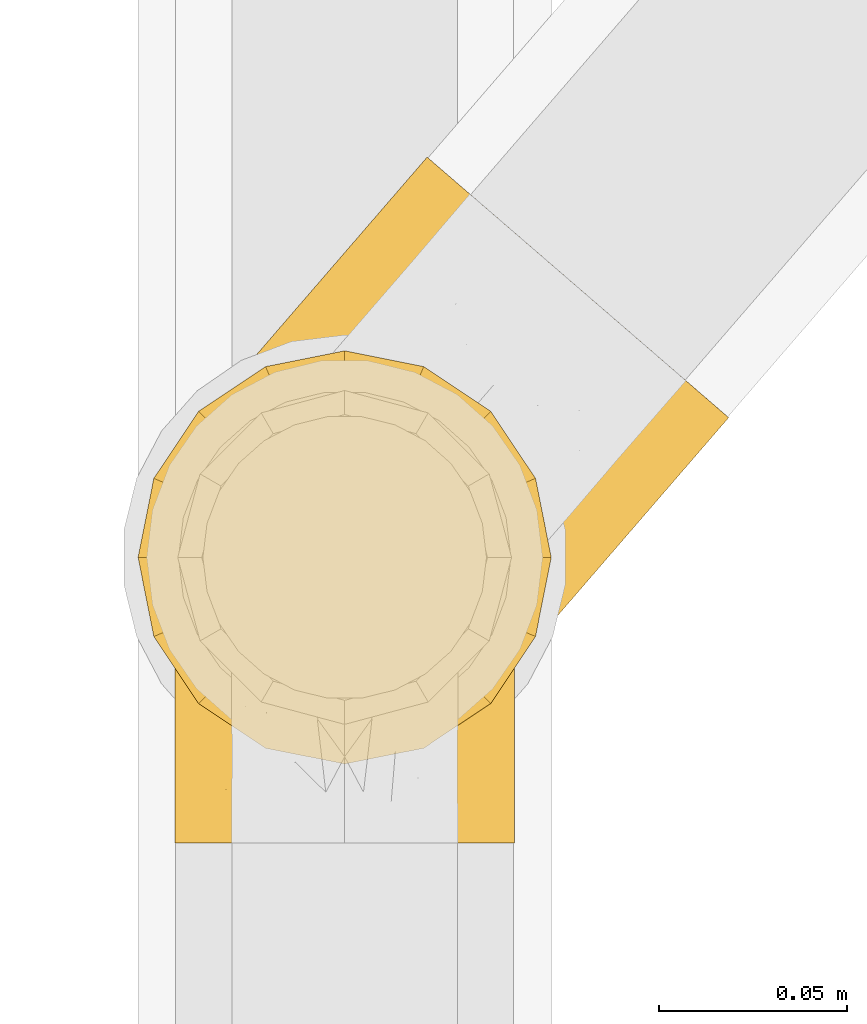
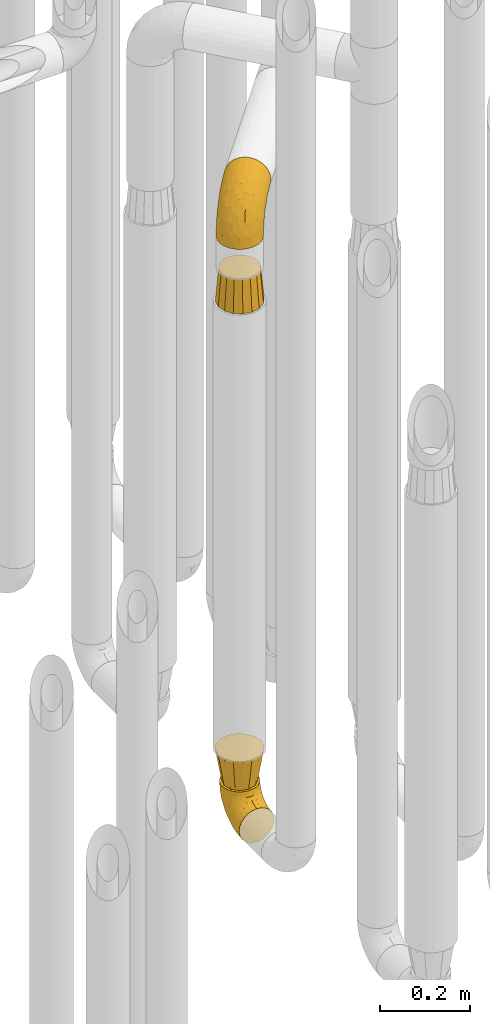
# One storey, part 215 of 827: 4 coverings.
"""IFC2X3 building model written with IfcOpenShell, lengths in millimetres."""

from ifc_helpers import new_model, entity, si_unit, converted_unit, derived_unit, direction, frame, origin, place, context, subcontext, project, spatial, faceted_brep, element, save


model = new_model("IFC2X3")

# Units and contexts
model_context = context("Model", 3, precision=0.01, world=origin(), true_north=direction((6.12303176911189e-17, 1.0)))
body_context = subcontext(model_context, "Body", "Model", "MODEL_VIEW")
ifc_project = project(units=[si_unit("LENGTHUNIT", "METRE", prefix="MILLI"), si_unit("AREAUNIT", "SQUARE_METRE"), si_unit("VOLUMEUNIT", "CUBIC_METRE"), converted_unit("PLANEANGLEUNIT", "DEGREE", entity("IfcRatioMeasure", 0.0174532925199433), si_unit("PLANEANGLEUNIT", "RADIAN"), dimensions=[0, 0, 0, 0, 0, 0, 0]), si_unit("MASSUNIT", "GRAM", prefix="KILO"), derived_unit("MASSDENSITYUNIT", [(si_unit("MASSUNIT", "GRAM", prefix="KILO"), 1), (si_unit("LENGTHUNIT", "METRE"), -3)]), derived_unit("MOMENTOFINERTIAUNIT", [(si_unit("LENGTHUNIT", "METRE"), 4)]), si_unit("TIMEUNIT", "SECOND"), si_unit("FREQUENCYUNIT", "HERTZ"), si_unit("THERMODYNAMICTEMPERATUREUNIT", "DEGREE_CELSIUS"), derived_unit("THERMALTRANSMITTANCEUNIT", [(si_unit("MASSUNIT", "GRAM", prefix="KILO"), 1), (si_unit("THERMODYNAMICTEMPERATUREUNIT", "KELVIN"), -1), (si_unit("TIMEUNIT", "SECOND"), -3)]), derived_unit("VOLUMETRICFLOWRATEUNIT", [(si_unit("LENGTHUNIT", "METRE"), 3), (si_unit("TIMEUNIT", "SECOND"), -1)]), derived_unit("MASSFLOWRATEUNIT", [(si_unit("MASSUNIT", "GRAM", prefix="KILO"), 1), (si_unit("TIMEUNIT", "SECOND"), -1)]), derived_unit("ROTATIONALFREQUENCYUNIT", [(si_unit("TIMEUNIT", "SECOND"), -1)]), si_unit("ELECTRICCURRENTUNIT", "AMPERE"), si_unit("ELECTRICVOLTAGEUNIT", "VOLT"), si_unit("POWERUNIT", "WATT"), si_unit("FORCEUNIT", "NEWTON", prefix="KILO"), si_unit("ILLUMINANCEUNIT", "LUX"), si_unit("LUMINOUSFLUXUNIT", "LUMEN"), si_unit("LUMINOUSINTENSITYUNIT", "CANDELA"), derived_unit("USERDEFINED", [(si_unit("MASSUNIT", "GRAM", prefix="KILO"), -1), (si_unit("LENGTHUNIT", "METRE"), -2), (si_unit("TIMEUNIT", "SECOND"), 3), (si_unit("LUMINOUSFLUXUNIT", "LUMEN"), 1)]), derived_unit("LINEARVELOCITYUNIT", [(si_unit("LENGTHUNIT", "METRE"), 1), (si_unit("TIMEUNIT", "SECOND"), -1)]), si_unit("PRESSUREUNIT", "PASCAL"), derived_unit("USERDEFINED", [(si_unit("LENGTHUNIT", "METRE"), -2), (si_unit("MASSUNIT", "GRAM", prefix="KILO"), 1), (si_unit("TIMEUNIT", "SECOND"), -2)]), derived_unit("LINEARFORCEUNIT", [(si_unit("MASSUNIT", "GRAM", prefix="KILO"), 1), (si_unit("LENGTHUNIT", "METRE"), 1), (si_unit("TIMEUNIT", "SECOND"), -2), (si_unit("LENGTHUNIT", "METRE"), -1)]), derived_unit("PLANARFORCEUNIT", [(si_unit("MASSUNIT", "GRAM", prefix="KILO"), 1), (si_unit("LENGTHUNIT", "METRE"), 1), (si_unit("TIMEUNIT", "SECOND"), -2), (si_unit("LENGTHUNIT", "METRE"), -2)])], contexts=[model_context])

# Site, building, storey
site_placement = place(None, origin())
site = spatial("IfcSite", under=ifc_project, at=site_placement, CompositionType="ELEMENT")
building_placement = place(site_placement, origin())
building = spatial("IfcBuilding", under=site, at=building_placement, CompositionType="ELEMENT")
storey_placement = place(building_placement, frame((0.0, 0.0, 28200.0)))
storey = spatial("IfcBuildingStorey", under=building, at=storey_placement, Name="08", CompositionType="ELEMENT", Elevation=28200.0)

# Coverings
covering_1_placement = place(storey_placement, frame((36582.9, 11254.0, 353.25)))
element("IfcCovering", 1, at=covering_1_placement, inside=storey, Name=":ADSK_", ObjectType=":ADSK_", PredefinedType="INSULATION", context=body_context, shape_type="Brep", body=[
    faceted_brep([(90.76, 87.65, 122.75), (87.42, 97.19, 122.75), (82.04, 105.75, 122.75), (74.89, 112.9, 122.75), (66.33, 118.28, 122.75), (56.79, 121.61, 122.75), (46.75, 122.75, 122.75), (36.69, 121.61, 122.75), (27.15, 118.27, 122.75), (18.59, 112.89, 122.75), (11.44, 105.74, 122.75), (6.06, 97.18, 122.75), (2.73, 87.64, 122.75), (1.6, 77.6, 122.75), (2.73, 67.54, 122.75), (6.07, 58.0, 122.75), (11.45, 49.44, 122.75), (18.6, 42.29, 122.75), (27.16, 36.91, 122.75), (36.7, 33.58, 122.75), (46.75, 32.45, 122.75), (56.8, 33.58, 122.75), (66.34, 36.92, 122.75), (74.9, 42.3, 122.75), (82.05, 49.45, 122.75), (87.43, 58.01, 122.75), (90.76, 67.55, 122.75), (91.9, 77.6, 122.75), (35.06, 1.6, 90.36), (24.17, 1.6, 85.85), (14.82, 1.6, 78.67), (7.64, 1.6, 69.32), (3.13, 1.6, 58.43), (1.6, 1.6, 46.75), (3.13, 1.6, 35.06), (7.64, 1.6, 24.17), (14.82, 1.6, 14.82), (24.17, 1.6, 7.64), (35.06, 1.6, 3.13), (46.75, 1.6, 1.6), (58.43, 1.6, 3.13), (69.32, 1.6, 7.64), (78.67, 1.6, 14.82), (85.85, 1.6, 24.17), (90.36, 1.6, 35.06), (91.9, 1.6, 46.75), (90.36, 1.6, 58.43), (85.85, 1.6, 69.32), (78.67, 1.6, 78.67), (69.32, 1.6, 85.85), (58.43, 1.6, 90.36), (46.75, 1.6, 91.9), (46.75, 99.61, 51.54), (55.2, 95.26, 47.17), (46.75, 86.21, 38.13), (46.75, 39.03, 7.52), (54.53, 30.75, 5.85), (46.75, 23.8, 5.11), (59.63, 60.8, 19.2), (62.07, 85.37, 38.98), (71.86, 73.64, 35.02), (62.65, 31.01, 8.21), (71.33, 49.14, 19.28), (72.93, 23.88, 12.19), (91.2, 82.74, 101.39), (86.31, 43.48, 34.43), (80.89, 29.47, 20.95), (79.49, 56.38, 30.74), (90.68, 72.18, 72.93), (86.84, 72.24, 56.64), (87.38, 87.6, 80.81), (76.87, 107.24, 93.43), (83.73, 101.1, 100.76), (81.03, 95.16, 74.27), (91.9, 71.81, 93.66), (91.9, 63.57, 81.33), (91.9, 55.34, 69.01), (91.03, 23.66, 40.87), (87.58, 20.55, 29.38), (56.52, 107.97, 67.05), (46.75, 116.82, 85.31), (60.4, 117.03, 93.68), (91.9, 30.68, 52.53), (91.9, 21.51, 50.71), (91.9, 12.33, 48.88), (67.87, 106.17, 72.77), (90.35, 52.37, 51.21), (69.57, 114.51, 101.18), (46.75, 119.23, 100.54), (79.91, 78.37, 48.74), (91.9, 75.46, 112.01), (91.9, 73.63, 102.83), (74.99, 101.51, 73.88), (46.75, 72.81, 24.73), (91.9, 43.01, 60.77), (88.53, 92.6, 103.08), (72.65, 91.86, 54.8), (46.75, 55.92, 16.13), (62.97, 99.01, 55.92), (46.75, 108.21, 68.42), (66.2, 32.05, 104.98), (56.6, 30.22, 108.58), (59.89, 23.37, 98.21), (90.95, 28.43, 61.56), (90.22, 16.44, 60.69), (76.64, 37.1, 100.0), (71.58, 28.88, 95.88), (79.99, 33.93, 90.81), (89.54, 50.17, 84.88), (89.97, 40.57, 73.29), (81.32, 47.62, 113.4), (74.56, 39.9, 109.8), (84.15, 47.92, 102.13), (90.37, 34.27, 67.29), (87.82, 24.65, 70.34), (90.98, 62.6, 95.15), (90.96, 66.18, 105.49), (85.14, 11.74, 71.5), (58.11, 13.89, 92.87), (46.75, 17.02, 96.03), (78.39, 15.86, 81.34), (88.22, 57.71, 107.44), (66.06, 9.11, 88.36), (68.6, 18.55, 90.43), (63.78, 34.74, 114.37), (88.42, 54.95, 98.41), (90.61, 57.35, 88.73), (83.8, 22.03, 76.89), (77.98, 24.8, 86.08), (91.22, 69.07, 112.64), (83.46, 42.31, 94.21), (46.75, 29.63, 112.22), (46.75, 28.31, 107.32), (84.66, 30.23, 79.95), (86.33, 40.13, 84.51), (46.75, 22.67, 101.67), (46.75, 12.12, 94.71), (15.1, 15.86, 81.34), (9.69, 22.03, 76.89), (15.52, 24.8, 86.08), (8.83, 30.23, 79.96), (35.39, 13.88, 92.87), (12.18, 47.61, 113.41), (1.6, 73.63, 102.83), (2.53, 66.17, 105.5), (2.27, 69.07, 112.64), (36.9, 30.22, 108.58), (27.31, 32.04, 104.98), (33.62, 23.36, 98.2), (5.07, 54.93, 98.4), (9.36, 47.91, 102.13), (5.27, 57.69, 107.44), (27.43, 9.1, 88.36), (1.6, 21.51, 50.71), (1.6, 12.33, 48.88), (10.05, 42.29, 94.22), (16.87, 37.09, 100.01), (8.35, 11.74, 71.5), (3.27, 16.44, 60.69), (1.6, 30.68, 52.53), (21.94, 28.86, 95.89), (29.72, 34.74, 114.37), (1.6, 63.57, 81.33), (1.6, 55.34, 69.01), (3.96, 50.17, 84.88), (1.6, 75.46, 112.01), (18.95, 39.89, 109.8), (2.54, 28.43, 61.56), (3.12, 34.27, 67.29), (1.6, 43.01, 60.77), (2.51, 62.59, 95.14), (3.52, 40.57, 73.29), (7.17, 40.13, 84.53), (1.6, 71.81, 93.66), (13.52, 33.92, 90.82), (2.88, 57.34, 88.73), (5.67, 24.65, 70.34), (24.89, 18.54, 90.43), (12.6, 29.47, 20.95), (7.18, 43.48, 34.43), (14.0, 56.4, 30.74), (22.16, 49.17, 19.29), (21.61, 73.69, 35.07), (3.14, 52.37, 51.21), (6.65, 72.26, 56.67), (20.82, 91.88, 54.85), (31.41, 85.36, 38.98), (5.91, 20.55, 29.38), (2.46, 23.66, 40.87), (33.87, 60.8, 19.2), (30.84, 31.02, 8.21), (38.96, 30.75, 5.85), (20.56, 23.9, 12.19), (2.81, 72.17, 72.93), (6.1, 87.59, 80.83), (2.29, 82.74, 101.39), (33.08, 117.03, 93.69), (16.61, 107.23, 93.43), (36.96, 107.97, 67.04), (9.75, 101.08, 100.76), (25.61, 106.17, 72.78), (30.5, 99.01, 55.93), (23.91, 114.5, 101.18), (12.45, 95.15, 74.27), (18.49, 101.5, 73.89), (4.96, 92.59, 103.09), (13.56, 78.38, 48.78), (38.28, 95.27, 47.19)], [[[0, 1, 2, 3, 4, 5, 6, 7, 8, 9, 10, 11, 12, 13, 14, 15, 16, 17, 18, 19, 20, 21, 22, 23, 24, 25, 26, 27]], [[28, 29, 30, 31, 32, 33, 34, 35, 36, 37, 38, 39, 40, 41, 42, 43, 44, 45, 46, 47, 48, 49, 50, 51]], [[52, 53, 54]], [[55, 56, 57]], [[58, 59, 60]], [[61, 62, 63]], [[27, 64, 0]], [[65, 66, 67]], [[41, 40, 61]], [[68, 69, 70]], [[66, 43, 42]], [[63, 42, 41]], [[71, 72, 73]], [[72, 2, 1]], [[68, 74, 75, 76]], [[45, 44, 77]], [[43, 78, 44]], [[79, 80, 81]], [[77, 82, 83, 84, 45]], [[79, 81, 85]], [[71, 2, 72]], [[65, 86, 77]], [[4, 81, 5]], [[66, 65, 78]], [[4, 3, 87]], [[81, 88, 5]], [[63, 66, 42]], [[68, 70, 64]], [[67, 60, 89]], [[71, 3, 2]], [[64, 27, 90, 91, 74]], [[92, 71, 73]], [[40, 57, 56]], [[59, 93, 54]], [[86, 76, 94, 82]], [[1, 0, 95]], [[58, 62, 61]], [[60, 96, 89]], [[85, 81, 87]], [[56, 97, 58]], [[65, 67, 69]], [[87, 81, 4]], [[67, 89, 69]], [[61, 63, 41]], [[95, 72, 1]], [[73, 72, 70]], [[69, 73, 70]], [[73, 89, 96]], [[3, 71, 87]], [[85, 87, 71]], [[58, 61, 56]], [[59, 58, 93]], [[76, 86, 68]], [[69, 89, 73]], [[68, 86, 69]], [[65, 69, 86]], [[68, 64, 74]], [[95, 64, 70]], [[98, 79, 85]], [[79, 52, 99, 80]], [[66, 62, 67]], [[62, 58, 60]], [[62, 60, 67]], [[59, 98, 96]], [[59, 96, 60]], [[96, 85, 92]], [[88, 81, 80]], [[88, 6, 5]], [[66, 63, 62]], [[64, 95, 0]], [[72, 95, 70]], [[77, 44, 78]], [[86, 82, 77]], [[40, 39, 57]], [[96, 98, 85]], [[40, 56, 61]], [[66, 78, 43]], [[77, 78, 65]], [[79, 98, 53]], [[96, 92, 73]], [[85, 71, 92]], [[97, 56, 55]], [[97, 93, 58]], [[53, 98, 59]], [[54, 53, 59]], [[79, 53, 52]], [[100, 101, 102]], [[46, 45, 84, 83]], [[103, 104, 82]], [[82, 104, 83]], [[105, 106, 107]], [[108, 109, 76]], [[110, 111, 112]], [[103, 113, 114]], [[115, 74, 116]], [[48, 47, 117]], [[118, 102, 119]], [[49, 48, 120]], [[74, 91, 116]], [[116, 121, 115]], [[49, 122, 50]], [[123, 106, 102]], [[124, 111, 22]], [[125, 126, 115]], [[23, 22, 111]], [[24, 110, 121]], [[120, 127, 128]], [[90, 26, 129]], [[27, 26, 90]], [[121, 125, 115]], [[24, 121, 25]], [[130, 105, 107]], [[129, 25, 116]], [[21, 20, 131]], [[120, 123, 122]], [[112, 105, 130]], [[50, 118, 51]], [[21, 124, 22]], [[101, 131, 132]], [[117, 120, 48]], [[24, 23, 110]], [[127, 114, 133]], [[75, 108, 76]], [[107, 134, 130]], [[133, 114, 113]], [[129, 116, 91]], [[25, 121, 116]], [[121, 112, 125]], [[75, 74, 115]], [[101, 135, 102]], [[131, 101, 21]], [[101, 100, 124]], [[128, 127, 133]], [[119, 136, 51, 118]], [[104, 47, 46]], [[83, 104, 46]], [[117, 104, 114]], [[101, 124, 21]], [[111, 124, 100]], [[102, 118, 123]], [[133, 134, 107]], [[111, 110, 23]], [[114, 104, 103]], [[94, 76, 109]], [[121, 110, 112]], [[122, 118, 50]], [[134, 109, 108]], [[133, 107, 128]], [[112, 108, 125]], [[126, 125, 108]], [[108, 75, 126]], [[75, 115, 126]], [[109, 134, 133]], [[130, 108, 112]], [[108, 130, 134]], [[105, 112, 111]], [[111, 100, 105]], [[106, 105, 100]], [[102, 106, 100]], [[128, 106, 123]], [[90, 129, 91]], [[25, 129, 26]], [[104, 117, 47]], [[117, 114, 127]], [[82, 94, 103]], [[113, 94, 109]], [[94, 113, 103]], [[133, 113, 109]], [[106, 128, 107]], [[123, 120, 128]], [[120, 122, 49]], [[118, 122, 123]], [[135, 101, 132]], [[135, 119, 102]], [[117, 127, 120]], [[30, 29, 137]], [[138, 139, 140]], [[51, 136, 119, 141]], [[142, 17, 16]], [[143, 144, 145]], [[146, 147, 148]], [[149, 150, 151]], [[152, 29, 28]], [[33, 32, 153, 154]], [[150, 155, 156]], [[157, 31, 30]], [[153, 158, 159]], [[29, 152, 137]], [[148, 141, 119]], [[156, 160, 147]], [[148, 135, 146]], [[137, 138, 157]], [[19, 161, 146]], [[162, 163, 164]], [[14, 13, 165]], [[153, 32, 158]], [[147, 161, 166]], [[18, 17, 166]], [[167, 168, 169]], [[166, 150, 156]], [[151, 150, 142]], [[151, 170, 149]], [[151, 16, 15]], [[171, 140, 172]], [[165, 143, 145]], [[173, 170, 144]], [[142, 166, 17]], [[19, 131, 20]], [[144, 170, 151]], [[18, 161, 19]], [[173, 144, 143]], [[140, 139, 174]], [[171, 164, 163]], [[164, 172, 155]], [[151, 15, 144]], [[145, 15, 14]], [[173, 162, 170]], [[149, 175, 164]], [[19, 146, 131]], [[132, 131, 146]], [[160, 148, 147]], [[159, 158, 167]], [[135, 132, 146]], [[158, 32, 31]], [[157, 158, 31]], [[167, 158, 176]], [[166, 161, 18]], [[146, 161, 147]], [[148, 177, 141]], [[171, 168, 140]], [[171, 163, 169]], [[151, 142, 16]], [[166, 142, 150]], [[152, 141, 177]], [[51, 141, 28]], [[138, 140, 176]], [[172, 140, 174]], [[175, 149, 170]], [[164, 150, 149]], [[170, 162, 175]], [[162, 164, 175]], [[155, 172, 174]], [[171, 172, 164]], [[155, 174, 156]], [[164, 155, 150]], [[160, 156, 174]], [[147, 166, 156]], [[139, 160, 174]], [[148, 160, 177]], [[15, 145, 144]], [[165, 145, 14]], [[137, 157, 30]], [[158, 157, 176]], [[168, 167, 176]], [[169, 159, 167]], [[140, 168, 176]], [[169, 168, 171]], [[137, 177, 139]], [[160, 139, 177]], [[141, 152, 28]], [[137, 152, 177]], [[148, 119, 135]], [[157, 138, 176]], [[139, 138, 137]], [[178, 179, 180]], [[181, 180, 182]], [[179, 183, 184]], [[185, 186, 182]], [[187, 188, 179]], [[188, 33, 154, 153, 159]], [[181, 189, 190]], [[35, 34, 187]], [[191, 38, 190]], [[192, 178, 181]], [[179, 184, 180]], [[192, 190, 37]], [[37, 190, 38]], [[36, 35, 178]], [[54, 93, 186]], [[35, 187, 178]], [[193, 194, 184]], [[195, 173, 143, 165, 13]], [[195, 193, 173]], [[193, 163, 162, 173]], [[13, 12, 195]], [[8, 7, 196]], [[9, 197, 10]], [[198, 80, 99, 52]], [[196, 7, 88]], [[197, 199, 10]], [[182, 189, 181]], [[200, 198, 201]], [[200, 196, 198]], [[9, 8, 202]], [[194, 199, 203]], [[192, 37, 36]], [[80, 196, 88]], [[183, 159, 169, 163]], [[188, 34, 33]], [[202, 200, 197]], [[185, 203, 204]], [[202, 8, 196]], [[10, 199, 11]], [[12, 11, 205]], [[38, 191, 57]], [[189, 97, 191]], [[203, 199, 197]], [[205, 199, 194]], [[204, 203, 197]], [[184, 203, 206]], [[200, 202, 196]], [[197, 9, 202]], [[207, 54, 186]], [[97, 55, 191]], [[194, 203, 184]], [[183, 163, 193]], [[184, 206, 180]], [[183, 193, 184]], [[205, 195, 12]], [[193, 195, 194]], [[80, 198, 196]], [[207, 186, 201]], [[182, 180, 206]], [[181, 178, 180]], [[185, 182, 206]], [[182, 186, 189]], [[203, 185, 206]], [[185, 200, 201]], [[7, 6, 88]], [[178, 192, 36]], [[190, 192, 181]], [[199, 205, 11]], [[195, 205, 194]], [[159, 183, 188]], [[179, 188, 183]], [[57, 191, 55]], [[57, 39, 38]], [[189, 191, 190]], [[188, 187, 34]], [[178, 187, 179]], [[186, 93, 189]], [[197, 200, 204]], [[185, 204, 200]], [[189, 93, 97]], [[207, 198, 52]], [[185, 201, 186]], [[198, 207, 201]], [[54, 207, 52]]]),
])
covering_2_placement = place(storey_placement, frame((36575.14, 11277.09, 1953.4)))
element("IfcCovering", 2, at=covering_2_placement, inside=storey, Name=":ADSK_", ObjectType=":ADSK_", PredefinedType="INSULATION", context=body_context, shape_type="Brep", body=[
    faceted_brep([(107.67, 134.11, 148.32), (116.6, 126.4, 149.65), (125.54, 118.68, 148.31), (134.02, 111.35, 144.39), (141.64, 104.78, 138.06), (147.99, 99.29, 129.66), (152.77, 95.16, 119.6), (155.74, 92.6, 108.39), (156.75, 91.73, 96.6), (155.74, 92.6, 84.79), (152.77, 95.16, 73.57), (147.98, 99.3, 63.51), (141.62, 104.79, 55.11), (134.01, 111.36, 48.79), (125.52, 118.69, 44.87), (116.6, 126.4, 43.55), (107.66, 134.12, 44.88), (99.17, 141.45, 48.8), (91.56, 148.03, 55.13), (85.2, 153.52, 63.53), (80.42, 157.65, 73.59), (77.45, 160.21, 84.8), (76.45, 161.08, 96.6), (77.46, 160.21, 108.41), (80.43, 157.64, 119.62), (85.21, 153.51, 129.68), (91.57, 148.02, 138.08), (99.19, 141.44, 144.4), (98.39, 84.31, 1.6), (104.61, 71.94, 1.6), (107.41, 58.38, 1.6), (106.61, 44.55, 1.6), (102.26, 31.4, 1.6), (94.65, 19.83, 1.6), (84.31, 10.62, 1.6), (71.94, 4.4, 1.6), (58.38, 1.6, 1.6), (44.55, 2.4, 1.6), (31.4, 6.75, 1.6), (19.83, 14.35, 1.6), (10.62, 24.7, 1.6), (4.4, 37.07, 1.6), (1.6, 50.63, 1.6), (2.4, 64.46, 1.6), (6.75, 77.61, 1.6), (14.35, 89.18, 1.6), (24.7, 98.39, 1.6), (37.07, 104.61, 1.6), (50.63, 107.41, 1.6), (64.46, 106.61, 1.6), (77.61, 102.26, 1.6), (89.18, 94.65, 1.6), (4.6, 43.97, 27.97), (10.75, 32.58, 37.09), (11.35, 49.1, 58.27), (14.61, 22.96, 27.13), (23.13, 18.17, 39.91), (40.19, 102.31, 109.11), (26.63, 81.46, 94.41), (38.06, 81.09, 110.94), (28.38, 49.84, 89.69), (32.79, 29.37, 75.62), (48.17, 47.17, 106.28), (14.38, 82.75, 60.12), (6.93, 70.2, 41.41), (12.66, 74.07, 63.22), (8.85, 79.33, 32.05), (17.15, 91.03, 52.13), (52.18, 105.6, 123.27), (57.44, 96.06, 129.32), (74.21, 118.09, 138.3), (16.51, 40.14, 62.95), (19.99, 29.06, 55.89), (4.75, 58.25, 37.4), (91.55, 97.4, 144.6), (80.99, 109.79, 142.66), (48.25, 68.16, 117.85), (66.53, 85.87, 134.01), (26.94, 93.1, 89.25), (60.75, 141.51, 103.34), (61.06, 136.99, 113.52), (26.21, 102.91, 57.43), (21.8, 97.8, 44.19), (17.39, 92.7, 30.95), (27.75, 102.2, 77.98), (71.12, 128.74, 132.66), (58.19, 124.23, 121.52), (22.41, 63.02, 86.93), (13.44, 66.09, 68.4), (39.95, 118.82, 78.45), (33.08, 110.86, 67.94), (67.92, 151.2, 94.53), (57.26, 138.86, 91.95), (44.1, 122.24, 93.36), (48.61, 128.84, 85.2), (41.39, 114.03, 101.45), (68.21, 70.38, 129.81), (15.87, 90.94, 16.27), (84.66, 123.6, 42.46), (72.54, 120.72, 40.4), (69.68, 127.87, 49.71), (29.44, 104.45, 39.4), (37.2, 107.83, 31.26), (26.84, 101.17, 27.7), (23.24, 97.73, 16.7), (52.59, 129.87, 70.67), (58.65, 139.0, 81.69), (36.2, 105.13, 16.68), (92.85, 98.91, 22.57), (91.4, 97.22, 14.26), (80.23, 104.28, 17.68), (53.66, 109.7, 19.58), (53.51, 114.06, 33.49), (64.11, 115.28, 33.01), (96.2, 119.91, 40.69), (108.32, 116.82, 40.15), (102.89, 110.53, 37.93), (84.5, 111.08, 31.04), (46.85, 116.28, 45.29), (69.41, 110.3, 23.55), (69.57, 106.34, 11.36), (40.22, 116.38, 59.1), (53.33, 124.87, 57.42), (43.45, 121.37, 68.96), (43.93, 108.21, 20.38), (67.53, 143.7, 72.46), (68.16, 149.48, 83.66), (66.67, 135.07, 60.66), (78.27, 143.79, 61.01), (81.44, 135.04, 51.85), (94.55, 131.12, 46.07), (97.87, 104.72, 30.25), (35.71, 110.22, 46.65), (60.92, 120.42, 43.0), (109.23, 61.7, 19.58), (140.85, 80.39, 72.44), (100.01, 87.2, 17.67), (120.25, 49.47, 78.45), (122.27, 53.3, 68.97), (129.34, 63.58, 70.65), (113.13, 105.28, 40.69), (118.47, 94.41, 42.45), (106.11, 92.44, 31.04), (118.78, 70.47, 42.99), (116.68, 55.86, 45.18), (113.57, 62.25, 33.46), (132.43, 78.28, 60.64), (124.27, 63.59, 57.37), (106.51, 33.56, 57.43), (102.1, 28.45, 44.19), (107.56, 36.99, 39.35), (96.17, 21.59, 16.27), (101.82, 29.86, 16.7), (137.56, 69.51, 91.95), (128.9, 59.49, 85.2), (137.47, 70.87, 81.68), (112.33, 43.96, 46.68), (109.79, 45.14, 31.26), (107.25, 43.76, 16.68), (104.7, 33.93, 27.7), (139.37, 91.02, 60.99), (130.25, 92.9, 51.84), (117.4, 82.02, 40.41), (124.88, 80.21, 49.72), (124.46, 105.29, 46.06), (148.22, 81.85, 94.53), (103.59, 76.95, 11.35), (113.23, 72.91, 33.02), (146.47, 81.84, 83.65), (109.18, 51.86, 20.38), (113.38, 41.51, 67.94), (117.8, 49.36, 59.12), (107.53, 77.37, 23.53), (97.69, 23.35, 30.95), (55.44, 11.03, 58.27), (51.34, 3.6, 27.97), (65.45, 5.82, 37.4), (76.96, 9.72, 41.41), (29.12, 10.45, 27.21), (39.18, 8.03, 37.09), (33.69, 15.86, 53.2), (96.08, 22.87, 52.13), (139.67, 73.35, 103.34), (135.17, 73.0, 113.5), (115.3, 50.19, 101.45), (85.23, 30.85, 94.41), (103.9, 47.29, 109.08), (83.23, 42.12, 110.95), (123.03, 54.08, 93.36), (105.59, 34.98, 77.98), (85.72, 12.95, 32.05), (45.76, 15.62, 64.63), (105.41, 59.63, 123.25), (125.55, 81.75, 132.65), (95.22, 63.46, 129.32), (119.6, 89.05, 139.96), (68.92, 50.3, 117.85), (53.69, 27.98, 89.69), (122.98, 68.31, 121.51), (79.95, 15.96, 63.23), (96.67, 32.8, 89.17), (105.37, 88.75, 142.66), (71.94, 15.56, 68.4), (67.6, 24.0, 86.94), (88.29, 18.92, 60.12), (85.71, 69.09, 133.2)], [[[0, 1, 2, 3, 4, 5, 6, 7, 8, 9, 10, 11, 12, 13, 14, 15, 16, 17, 18, 19, 20, 21, 22, 23, 24, 25, 26, 27]], [[28, 29, 30, 31, 32, 33, 34, 35, 36, 37, 38, 39, 40, 41, 42, 43, 44, 45, 46, 47, 48, 49, 50, 51]], [[52, 53, 54]], [[55, 39, 56]], [[57, 58, 59]], [[60, 61, 62]], [[63, 64, 65]], [[66, 63, 67]], [[68, 69, 70]], [[53, 71, 54]], [[41, 40, 53]], [[53, 72, 71]], [[73, 42, 52]], [[42, 41, 52]], [[74, 0, 75]], [[69, 76, 77]], [[43, 73, 64]], [[45, 44, 66]], [[57, 78, 58]], [[23, 79, 80]], [[67, 81, 82, 83]], [[67, 84, 81]], [[24, 23, 80]], [[25, 85, 26]], [[86, 85, 25]], [[42, 73, 43]], [[0, 27, 75]], [[25, 24, 86]], [[70, 26, 85]], [[0, 74, 1]], [[68, 85, 86]], [[66, 64, 63]], [[60, 59, 87]], [[54, 87, 88]], [[76, 60, 62]], [[84, 89, 90, 81]], [[79, 22, 91, 92]], [[77, 74, 75]], [[93, 92, 94, 89]], [[80, 86, 24]], [[40, 55, 53]], [[76, 59, 60]], [[93, 84, 95]], [[76, 62, 96]], [[55, 72, 53]], [[70, 27, 26]], [[75, 70, 69]], [[78, 84, 63]], [[93, 79, 92]], [[95, 86, 80]], [[77, 76, 96]], [[59, 69, 68]], [[57, 68, 86]], [[68, 57, 59]], [[59, 58, 87]], [[76, 69, 59]], [[88, 87, 58]], [[87, 54, 71]], [[86, 95, 57]], [[78, 57, 95]], [[84, 78, 95]], [[78, 63, 65]], [[58, 78, 65]], [[54, 88, 73]], [[84, 93, 89]], [[79, 95, 80]], [[79, 93, 95]], [[22, 79, 23]], [[66, 83, 97, 45]], [[84, 67, 63]], [[83, 66, 67]], [[64, 44, 43]], [[64, 66, 44]], [[65, 73, 88]], [[53, 52, 41]], [[73, 52, 54]], [[73, 65, 64]], [[65, 88, 58]], [[39, 55, 40]], [[72, 55, 56]], [[56, 61, 72]], [[60, 72, 61]], [[72, 60, 71]], [[87, 71, 60]], [[27, 70, 75]], [[68, 70, 85]], [[74, 77, 96]], [[69, 77, 75]], [[98, 99, 100]], [[46, 45, 97]], [[101, 102, 103]], [[103, 104, 83]], [[105, 94, 106]], [[107, 103, 102]], [[108, 109, 51, 110]], [[111, 112, 113]], [[114, 115, 116]], [[47, 104, 107]], [[110, 117, 108]], [[49, 48, 111]], [[102, 118, 112]], [[119, 120, 111]], [[50, 49, 120]], [[121, 122, 118]], [[105, 123, 89]], [[124, 48, 107]], [[20, 19, 125]], [[121, 81, 90]], [[117, 119, 99]], [[21, 20, 126]], [[22, 21, 91]], [[105, 125, 127]], [[110, 51, 50]], [[19, 128, 125]], [[16, 15, 115]], [[129, 98, 100]], [[126, 91, 21]], [[128, 129, 127]], [[122, 123, 105]], [[114, 117, 98]], [[17, 16, 130]], [[18, 128, 19]], [[129, 18, 17]], [[125, 106, 126]], [[115, 114, 16]], [[130, 129, 17]], [[114, 98, 130]], [[117, 116, 131, 108]], [[99, 119, 113]], [[122, 121, 123]], [[92, 126, 106]], [[105, 127, 122]], [[132, 121, 118]], [[114, 130, 16]], [[129, 130, 98]], [[50, 120, 110]], [[129, 128, 18]], [[125, 128, 127]], [[125, 126, 20]], [[91, 126, 92]], [[105, 89, 94]], [[105, 106, 125]], [[94, 92, 106]], [[100, 122, 127]], [[118, 122, 133]], [[112, 118, 133]], [[132, 118, 102]], [[132, 102, 101]], [[81, 121, 132]], [[82, 103, 83]], [[132, 101, 81]], [[104, 47, 46]], [[124, 107, 102]], [[48, 47, 107]], [[113, 112, 133]], [[112, 111, 124]], [[99, 113, 133]], [[111, 113, 119]], [[99, 133, 100]], [[117, 99, 98]], [[122, 100, 133]], [[127, 129, 100]], [[103, 82, 101]], [[81, 101, 82]], [[112, 124, 102]], [[48, 124, 111]], [[104, 103, 107]], [[46, 97, 104]], [[111, 120, 49]], [[83, 104, 97]], [[110, 120, 119]], [[117, 110, 119]], [[116, 117, 114]], [[123, 90, 89]], [[90, 123, 121]], [[30, 29, 134]], [[11, 10, 135]], [[51, 109, 108, 136]], [[137, 138, 139]], [[140, 141, 142]], [[143, 144, 145]], [[146, 139, 147]], [[148, 149, 150]], [[151, 32, 152]], [[153, 154, 155]], [[156, 150, 157]], [[158, 157, 159]], [[108, 142, 136]], [[31, 158, 152]], [[160, 161, 12]], [[162, 163, 143]], [[140, 142, 116]], [[142, 141, 162]], [[14, 164, 140]], [[14, 140, 115]], [[9, 8, 165]], [[160, 12, 11]], [[141, 164, 161]], [[13, 12, 161]], [[14, 115, 15]], [[28, 166, 29]], [[135, 139, 146]], [[141, 163, 162]], [[135, 146, 160]], [[143, 167, 162]], [[29, 166, 134]], [[116, 142, 108, 131]], [[165, 153, 168]], [[10, 9, 168]], [[168, 135, 10]], [[138, 147, 139]], [[158, 169, 157]], [[14, 13, 164]], [[116, 115, 140]], [[145, 167, 143]], [[135, 160, 11]], [[168, 153, 155]], [[138, 170, 171]], [[157, 144, 156]], [[147, 144, 143]], [[161, 164, 13]], [[140, 164, 141]], [[142, 172, 136]], [[136, 172, 166]], [[161, 160, 146]], [[165, 168, 9]], [[155, 139, 135]], [[139, 154, 137]], [[168, 155, 135]], [[139, 155, 154]], [[144, 147, 171]], [[163, 147, 143]], [[156, 144, 171]], [[157, 169, 145]], [[171, 148, 156]], [[173, 159, 149]], [[159, 157, 150]], [[152, 159, 173]], [[159, 152, 158]], [[31, 30, 158]], [[169, 30, 134]], [[157, 145, 144]], [[167, 134, 172]], [[134, 167, 145]], [[172, 142, 162]], [[162, 167, 172]], [[163, 141, 161]], [[161, 146, 163]], [[147, 163, 146]], [[148, 150, 156]], [[149, 159, 150]], [[30, 169, 158]], [[145, 169, 134]], [[151, 33, 32]], [[31, 152, 32]], [[152, 173, 151]], [[28, 51, 136]], [[134, 166, 172]], [[28, 136, 166]], [[147, 138, 171]], [[170, 138, 137]], [[170, 148, 171]], [[174, 175, 176]], [[35, 34, 177]], [[178, 179, 180]], [[181, 173, 149, 148]], [[182, 183, 184]], [[185, 186, 187]], [[188, 189, 137]], [[190, 33, 151, 173]], [[191, 179, 174]], [[34, 190, 177]], [[39, 38, 178]], [[192, 193, 194]], [[4, 3, 195]], [[175, 179, 37]], [[38, 37, 179]], [[35, 176, 36]], [[196, 62, 197]], [[181, 190, 173]], [[37, 36, 175]], [[183, 6, 198]], [[189, 148, 170, 137]], [[185, 199, 200]], [[3, 2, 201]], [[202, 185, 203]], [[8, 7, 182]], [[200, 184, 186]], [[183, 7, 6]], [[181, 189, 204]], [[200, 189, 184]], [[5, 198, 6]], [[187, 203, 185]], [[195, 3, 201]], [[205, 196, 194]], [[62, 61, 197]], [[186, 198, 192]], [[180, 179, 191]], [[2, 1, 74]], [[198, 193, 192]], [[193, 5, 4]], [[194, 193, 195]], [[2, 74, 201]], [[5, 193, 198]], [[205, 74, 96]], [[188, 137, 154, 153]], [[62, 196, 96]], [[56, 178, 180]], [[198, 184, 183]], [[184, 188, 182]], [[203, 197, 191]], [[205, 194, 201]], [[187, 192, 194]], [[192, 187, 186]], [[194, 196, 187]], [[197, 187, 196]], [[197, 203, 187]], [[202, 174, 176]], [[200, 186, 185]], [[184, 198, 186]], [[199, 185, 202]], [[189, 200, 204]], [[174, 202, 203]], [[176, 177, 199]], [[189, 181, 148]], [[190, 181, 204]], [[190, 204, 177]], [[190, 34, 33]], [[188, 153, 182]], [[189, 188, 184]], [[182, 153, 165, 8]], [[183, 182, 7]], [[199, 177, 204]], [[35, 177, 176]], [[176, 175, 36]], [[179, 175, 174]], [[200, 199, 204]], [[176, 199, 202]], [[203, 191, 174]], [[180, 197, 61]], [[197, 180, 191]], [[61, 56, 180]], [[39, 178, 56]], [[38, 179, 178]], [[194, 195, 201]], [[4, 195, 193]], [[74, 205, 201]], [[96, 196, 205]]]),
])
covering_3_placement = place(storey_placement, frame((36573.05, 11275.0, 1781.0)))
element("IfcCovering", 3, at=covering_3_placement, inside=storey, Name=":ADSK_", ObjectType=":ADSK_", PredefinedType="INSULATION", context=body_context, shape_type="Brep", body=[
    faceted_brep([(35.55, 107.41, 0.0), (43.51, 108.99, 0.0), (56.6, 111.6, 0.0), (69.69, 108.99, 0.0), (77.64, 107.41, 0.0), (86.56, 101.45, 0.0), (95.49, 95.49, 0.0), (101.45, 86.56, 0.0), (107.41, 77.64, 0.0), (108.99, 69.69, 0.0), (111.6, 56.6, 0.0), (108.99, 43.51, 0.0), (107.41, 35.55, 0.0), (101.45, 26.63, 0.0), (95.49, 17.7, 0.0), (86.56, 11.74, 0.0), (77.64, 5.78, 0.0), (69.69, 4.2, 0.0), (56.6, 1.6, 0.0), (43.51, 4.2, 0.0), (35.55, 5.78, 0.0), (26.63, 11.74, 0.0), (17.7, 17.7, 0.0), (11.74, 26.63, 0.0), (5.78, 35.55, 0.0), (4.2, 43.51, 0.0), (1.6, 56.6, 0.0), (4.2, 69.69, 0.0), (5.78, 77.64, 0.0), (11.74, 86.56, 0.0), (17.7, 95.49, 0.0), (26.63, 101.45, 0.0), (9.1, 56.6, 89.0), (10.9, 47.51, 89.0), (12.71, 38.42, 89.0), (17.86, 30.71, 89.0), (23.01, 23.01, 89.0), (30.71, 17.86, 89.0), (38.42, 12.71, 89.0), (47.51, 10.9, 89.0), (56.6, 9.1, 89.0), (65.68, 10.9, 89.0), (74.77, 12.71, 89.0), (82.48, 17.86, 89.0), (90.18, 23.01, 89.0), (95.33, 30.71, 89.0), (100.48, 38.42, 89.0), (102.29, 47.51, 89.0), (104.1, 56.6, 89.0), (102.29, 65.68, 89.0), (100.48, 74.77, 89.0), (95.33, 82.48, 89.0), (90.18, 90.18, 89.0), (82.48, 95.33, 89.0), (74.77, 100.48, 89.0), (65.68, 102.29, 89.0), (56.6, 104.1, 89.0), (47.51, 102.29, 89.0), (38.42, 100.48, 89.0), (30.71, 95.33, 89.0), (23.01, 90.18, 89.0), (17.86, 82.48, 89.0), (12.71, 74.77, 89.0), (10.9, 65.68, 89.0)], [[[0, 1, 2, 3, 4, 5, 6, 7, 8, 9, 10, 11, 12, 13, 14, 15, 16, 17, 18, 19, 20, 21, 22, 23, 24, 25, 26, 27, 28, 29, 30, 31]], [[32, 33, 34, 35, 36, 37, 38, 39, 40, 41, 42, 43, 44, 45, 46, 47, 48, 49, 50, 51, 52, 53, 54, 55, 56, 57, 58, 59, 60, 61, 62, 63]], [[46, 12, 11, 10, 48, 47]], [[44, 14, 13, 12, 46, 45]], [[42, 16, 15, 14, 44, 43]], [[41, 40, 18, 17, 16, 42]], [[38, 20, 19, 18, 40, 39]], [[36, 22, 21, 20, 38, 37]], [[34, 24, 23, 22, 36, 35]], [[33, 32, 26, 25, 24, 34]], [[62, 28, 27, 26, 32, 63]], [[60, 30, 29, 28, 62, 61]], [[58, 0, 31, 30, 60, 59]], [[57, 56, 2, 1, 0, 58]], [[54, 4, 3, 2, 56, 55]], [[52, 6, 5, 4, 54, 53]], [[50, 8, 7, 6, 52, 51]], [[49, 48, 10, 9, 8, 50]]]),
])
covering_4_placement = place(storey_placement, frame((36573.05, 11275.0, 476.0)))
element("IfcCovering", 4, at=covering_4_placement, inside=storey, Name=":ADSK_", ObjectType=":ADSK_", PredefinedType="INSULATION", context=body_context, shape_type="Brep", body=[
    faceted_brep([(77.64, 107.41, 89.0), (67.12, 109.5, 89.0), (56.6, 111.6, 89.0), (46.07, 109.5, 89.0), (35.55, 107.41, 89.0), (26.63, 101.45, 89.0), (17.7, 95.49, 89.0), (11.74, 86.56, 89.0), (5.78, 77.64, 89.0), (3.69, 67.12, 89.0), (1.6, 56.6, 89.0), (3.69, 46.07, 89.0), (5.78, 35.55, 89.0), (11.74, 26.63, 89.0), (17.7, 17.7, 89.0), (26.63, 11.74, 89.0), (35.55, 5.78, 89.0), (46.07, 3.69, 89.0), (56.6, 1.6, 89.0), (67.12, 3.69, 89.0), (77.64, 5.78, 89.0), (86.56, 11.74, 89.0), (95.49, 17.7, 89.0), (101.45, 26.63, 89.0), (107.41, 35.55, 89.0), (109.5, 46.07, 89.0), (111.6, 56.6, 89.0), (109.5, 67.12, 89.0), (107.41, 77.64, 89.0), (101.45, 86.56, 89.0), (95.49, 95.49, 89.0), (86.56, 101.45, 89.0), (91.24, 36.6, 0.0), (83.92, 29.27, 0.0), (76.6, 21.95, 0.0), (66.6, 19.27, 0.0), (56.6, 16.6, 0.0), (46.6, 19.27, 0.0), (36.6, 21.95, 0.0), (29.27, 29.27, 0.0), (21.95, 36.6, 0.0), (19.27, 46.6, 0.0), (16.6, 56.6, 0.0), (19.27, 66.6, 0.0), (21.95, 76.6, 0.0), (29.27, 83.92, 0.0), (36.6, 91.24, 0.0), (46.6, 93.92, 0.0), (56.6, 96.6, 0.0), (66.6, 93.92, 0.0), (76.6, 91.24, 0.0), (83.92, 83.92, 0.0), (91.24, 76.6, 0.0), (93.92, 66.6, 0.0), (96.6, 56.6, 0.0), (93.92, 46.6, 0.0)], [[[0, 1, 2, 3, 4, 5, 6, 7, 8, 9, 10, 11, 12, 13, 14, 15, 16, 17, 18, 19, 20, 21, 22, 23, 24, 25, 26, 27, 28, 29, 30, 31]], [[32, 33, 34, 35, 36, 37, 38, 39, 40, 41, 42, 43, 44, 45, 46, 47, 48, 49, 50, 51, 52, 53, 54, 55]], [[3, 2, 48]], [[44, 7, 45]], [[45, 5, 46]], [[48, 47, 3]], [[6, 45, 7]], [[44, 8, 7]], [[5, 45, 6]], [[42, 9, 43]], [[5, 4, 46]], [[47, 46, 4]], [[9, 42, 10]], [[8, 44, 43]], [[9, 8, 43]], [[47, 4, 3]], [[11, 10, 42]], [[38, 15, 39]], [[39, 13, 40]], [[42, 41, 11]], [[14, 39, 15]], [[38, 16, 15]], [[13, 39, 14]], [[36, 17, 37]], [[13, 12, 40]], [[41, 40, 12]], [[17, 36, 18]], [[16, 38, 37]], [[17, 16, 37]], [[41, 12, 11]], [[19, 18, 36]], [[32, 23, 33]], [[33, 21, 34]], [[36, 35, 19]], [[22, 33, 23]], [[32, 24, 23]], [[21, 33, 22]], [[54, 25, 55]], [[21, 20, 34]], [[35, 34, 20]], [[25, 54, 26]], [[24, 32, 55]], [[25, 24, 55]], [[35, 20, 19]], [[27, 26, 54]], [[50, 31, 51]], [[51, 29, 52]], [[54, 53, 27]], [[30, 51, 31]], [[50, 0, 31]], [[29, 51, 30]], [[48, 1, 49]], [[29, 28, 52]], [[53, 52, 28]], [[1, 48, 2]], [[0, 50, 49]], [[1, 0, 49]], [[53, 28, 27]]]),
])

save(model, "model.ifc")
